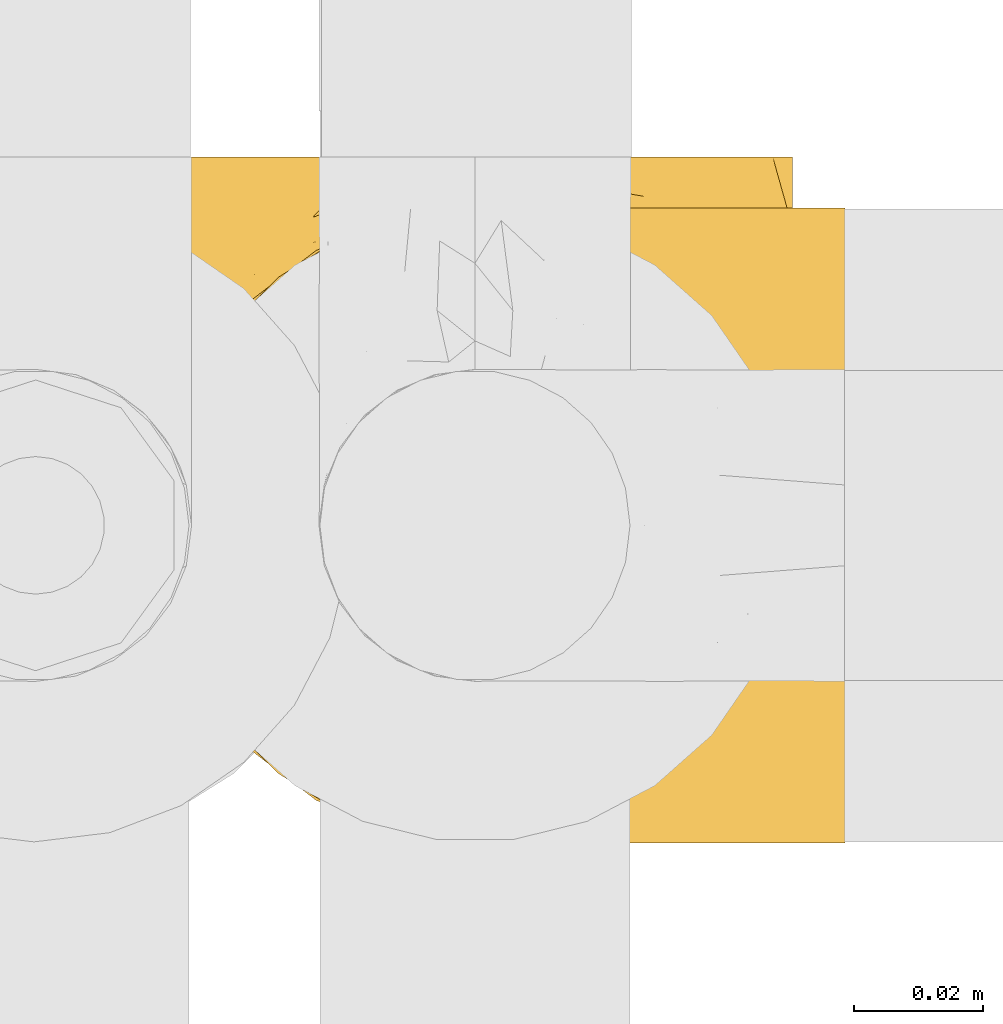
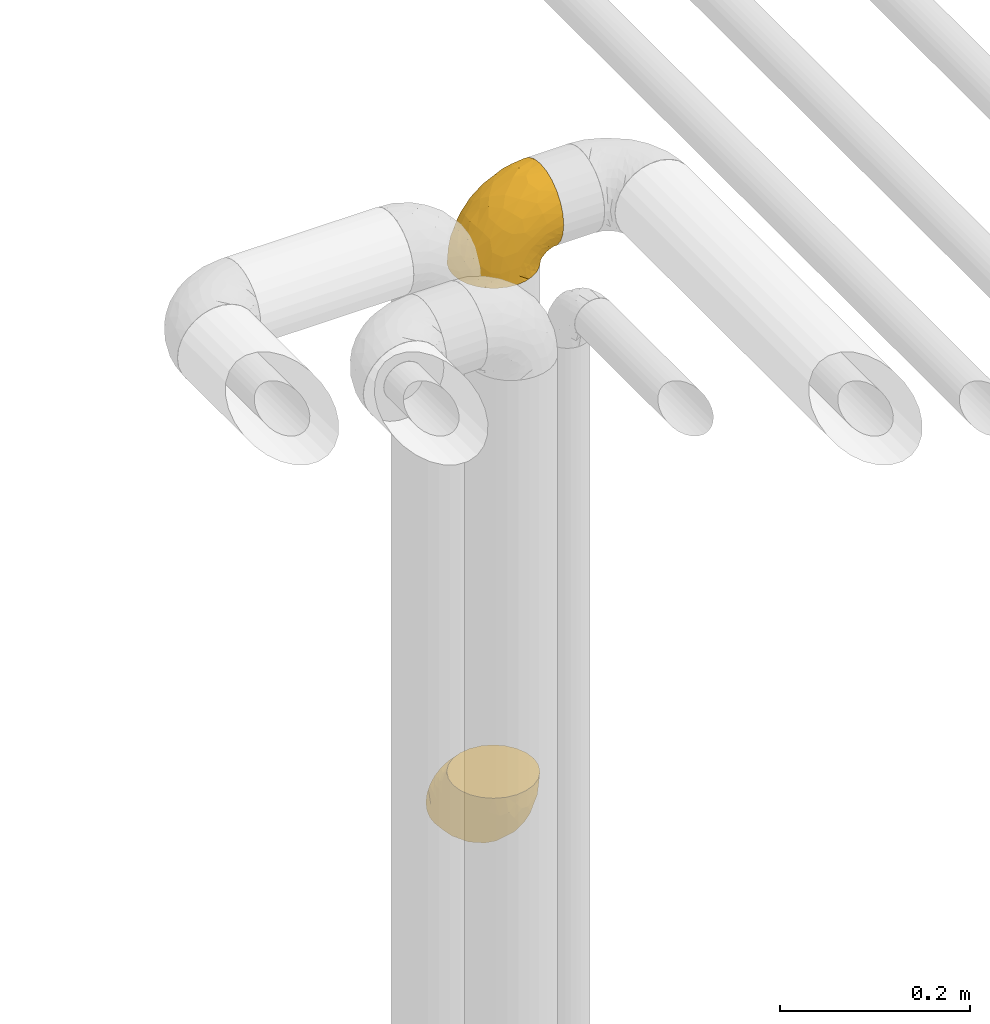
# One storey, part 402 of 827: 2 coverings.
"""IFC2X3 building model written with IfcOpenShell, lengths in millimetres."""

from ifc_helpers import new_model, entity, si_unit, converted_unit, derived_unit, direction, frame, origin, place, context, subcontext, project, spatial, faceted_brep, element, save


model = new_model("IFC2X3")

# Units and contexts
model_context = context("Model", 3, precision=0.01, world=origin(), true_north=direction((6.12303176911189e-17, 1.0)))
body_context = subcontext(model_context, "Body", "Model", "MODEL_VIEW")
ifc_project = project(units=[si_unit("LENGTHUNIT", "METRE", prefix="MILLI"), si_unit("AREAUNIT", "SQUARE_METRE"), si_unit("VOLUMEUNIT", "CUBIC_METRE"), converted_unit("PLANEANGLEUNIT", "DEGREE", entity("IfcRatioMeasure", 0.0174532925199433), si_unit("PLANEANGLEUNIT", "RADIAN"), dimensions=[0, 0, 0, 0, 0, 0, 0]), si_unit("MASSUNIT", "GRAM", prefix="KILO"), derived_unit("MASSDENSITYUNIT", [(si_unit("MASSUNIT", "GRAM", prefix="KILO"), 1), (si_unit("LENGTHUNIT", "METRE"), -3)]), derived_unit("MOMENTOFINERTIAUNIT", [(si_unit("LENGTHUNIT", "METRE"), 4)]), si_unit("TIMEUNIT", "SECOND"), si_unit("FREQUENCYUNIT", "HERTZ"), si_unit("THERMODYNAMICTEMPERATUREUNIT", "DEGREE_CELSIUS"), derived_unit("THERMALTRANSMITTANCEUNIT", [(si_unit("MASSUNIT", "GRAM", prefix="KILO"), 1), (si_unit("THERMODYNAMICTEMPERATUREUNIT", "KELVIN"), -1), (si_unit("TIMEUNIT", "SECOND"), -3)]), derived_unit("VOLUMETRICFLOWRATEUNIT", [(si_unit("LENGTHUNIT", "METRE"), 3), (si_unit("TIMEUNIT", "SECOND"), -1)]), derived_unit("MASSFLOWRATEUNIT", [(si_unit("MASSUNIT", "GRAM", prefix="KILO"), 1), (si_unit("TIMEUNIT", "SECOND"), -1)]), derived_unit("ROTATIONALFREQUENCYUNIT", [(si_unit("TIMEUNIT", "SECOND"), -1)]), si_unit("ELECTRICCURRENTUNIT", "AMPERE"), si_unit("ELECTRICVOLTAGEUNIT", "VOLT"), si_unit("POWERUNIT", "WATT"), si_unit("FORCEUNIT", "NEWTON", prefix="KILO"), si_unit("ILLUMINANCEUNIT", "LUX"), si_unit("LUMINOUSFLUXUNIT", "LUMEN"), si_unit("LUMINOUSINTENSITYUNIT", "CANDELA"), derived_unit("USERDEFINED", [(si_unit("MASSUNIT", "GRAM", prefix="KILO"), -1), (si_unit("LENGTHUNIT", "METRE"), -2), (si_unit("TIMEUNIT", "SECOND"), 3), (si_unit("LUMINOUSFLUXUNIT", "LUMEN"), 1)]), derived_unit("LINEARVELOCITYUNIT", [(si_unit("LENGTHUNIT", "METRE"), 1), (si_unit("TIMEUNIT", "SECOND"), -1)]), si_unit("PRESSUREUNIT", "PASCAL"), derived_unit("USERDEFINED", [(si_unit("LENGTHUNIT", "METRE"), -2), (si_unit("MASSUNIT", "GRAM", prefix="KILO"), 1), (si_unit("TIMEUNIT", "SECOND"), -2)]), derived_unit("LINEARFORCEUNIT", [(si_unit("MASSUNIT", "GRAM", prefix="KILO"), 1), (si_unit("LENGTHUNIT", "METRE"), 1), (si_unit("TIMEUNIT", "SECOND"), -2), (si_unit("LENGTHUNIT", "METRE"), -1)]), derived_unit("PLANARFORCEUNIT", [(si_unit("MASSUNIT", "GRAM", prefix="KILO"), 1), (si_unit("LENGTHUNIT", "METRE"), 1), (si_unit("TIMEUNIT", "SECOND"), -2), (si_unit("LENGTHUNIT", "METRE"), -2)])], contexts=[model_context])

# Site, building, storey
site_placement = place(None, origin())
site = spatial("IfcSite", under=ifc_project, at=site_placement, CompositionType="ELEMENT")
building_placement = place(site_placement, origin())
building = spatial("IfcBuilding", under=site, at=building_placement, CompositionType="ELEMENT")
storey_placement = place(building_placement, frame((0.0, 0.0, 28200.0)))
storey = spatial("IfcBuildingStorey", under=building, at=storey_placement, Name="08", CompositionType="ELEMENT", Elevation=28200.0)

# Coverings
covering_1_placement = place(storey_placement, frame((47669.52, 15256.28, 2941.4)))
element("IfcCovering", 1, at=covering_1_placement, inside=storey, Name=":ADSK_", ObjectType=":ADSK_", PredefinedType="INSULATION", context=body_context, shape_type="Brep", body=[
    faceted_brep([(50.75, 1.6, 1.6), (39.8, 2.83, 1.6), (29.41, 6.47, 1.6), (20.09, 12.32, 1.6), (12.31, 20.11, 1.6), (6.46, 29.43, 1.6), (2.83, 39.81, 1.6), (1.6, 50.75, 1.6), (2.83, 61.69, 1.6), (6.47, 72.08, 1.6), (12.32, 81.4, 1.6), (20.11, 89.18, 1.6), (29.43, 95.03, 1.6), (39.81, 98.66, 1.6), (50.75, 99.9, 1.6), (56.45, 99.25, 1.6), (61.69, 98.66, 1.6), (66.88, 96.84, 1.6), (72.08, 95.02, 1.6), (81.4, 89.17, 1.6), (89.18, 81.38, 1.6), (95.03, 72.06, 1.6), (98.66, 61.68, 1.6), (99.9, 50.75, 1.6), (98.66, 39.8, 1.6), (95.02, 29.41, 1.6), (89.17, 20.09, 1.6), (81.38, 12.31, 1.6), (72.06, 6.46, 1.6), (66.87, 4.64, 1.6), (61.68, 2.83, 1.6), (56.45, 2.24, 1.6), (53.6, 1.92, 1.6), (107.75, 63.47, 11.12), (107.75, 75.32, 16.03), (107.75, 80.41, 19.94), (107.75, 85.5, 23.84), (107.75, 89.4, 28.93), (107.75, 93.31, 34.02), (107.75, 95.77, 39.95), (107.75, 98.22, 45.87), (107.75, 99.14, 52.86), (107.75, 99.52, 55.73), (107.75, 99.9, 58.6), (107.75, 98.22, 71.32), (107.75, 93.31, 83.17), (107.75, 85.5, 93.35), (107.75, 75.32, 101.16), (107.75, 63.47, 106.07), (107.75, 50.75, 107.75), (107.75, 38.02, 106.07), (107.75, 26.17, 101.16), (107.75, 15.99, 93.35), (107.75, 8.18, 83.17), (107.75, 3.27, 71.32), (107.75, 1.6, 58.6), (107.75, 2.35, 52.86), (107.75, 3.27, 45.87), (107.75, 5.73, 39.95), (107.75, 8.18, 34.02), (107.75, 12.09, 28.93), (107.75, 15.99, 23.84), (107.75, 21.08, 19.94), (107.75, 26.17, 16.03), (107.75, 38.02, 11.12), (107.75, 50.75, 9.45), (39.38, 42.18, 81.82), (49.75, 28.42, 84.02), (57.38, 37.78, 93.05), (74.94, 50.75, 102.55), (85.97, 42.85, 104.83), (95.66, 50.75, 105.83), (67.82, 24.75, 91.87), (83.09, 33.81, 101.74), (89.16, 22.57, 97.07), (37.01, 7.18, 38.45), (43.46, 2.73, 22.17), (51.79, 3.09, 42.04), (85.58, 6.92, 77.69), (62.84, 11.58, 75.76), (62.77, 5.17, 62.11), (88.17, 2.71, 66.08), (85.93, 1.6, 54.26), (91.42, 1.6, 55.35), (96.91, 1.6, 56.44), (99.62, 1.6, 56.98), (102.33, 1.6, 57.52), (82.57, 14.18, 87.84), (32.75, 5.88, 19.41), (13.79, 41.06, 48.89), (6.77, 36.25, 26.34), (16.46, 28.62, 44.55), (55.08, 1.6, 23.41), (58.17, 1.6, 28.03), (61.26, 1.6, 32.65), (64.35, 1.6, 37.28), (67.44, 1.6, 41.9), (24.18, 10.85, 20.6), (23.37, 38.35, 63.36), (49.76, 9.6, 62.21), (9.84, 26.24, 19.94), (3.51, 50.75, 13.68), (55.75, 19.31, 80.85), (42.34, 16.41, 66.53), (37.78, 24.56, 71.06), (21.87, 50.75, 63.99), (33.61, 50.75, 75.73), (17.1, 18.47, 26.77), (51.28, 1.6, 4.31), (51.82, 1.6, 7.01), (52.9, 1.6, 12.43), (53.99, 1.6, 17.92), (28.01, 14.36, 43.43), (28.99, 20.64, 56.23), (69.9, 2.32, 54.97), (6.79, 50.75, 34.4), (72.06, 1.6, 44.99), (76.69, 1.6, 48.08), (81.31, 1.6, 51.17), (45.35, 50.75, 87.47), (34.79, 33.88, 74.55), (25.72, 29.24, 60.86), (14.33, 50.75, 49.19), (60.15, 50.75, 95.01), (62.38, 2.8, 10.27), (100.57, 2.48, 48.79), (91.06, 2.7, 45.16), (97.66, 3.2, 44.99), (97.55, 32.98, 6.17), (93.65, 24.67, 7.65), (66.85, 2.95, 21.59), (61.93, 2.19, 19.96), (101.4, 17.92, 21.0), (100.07, 12.02, 27.2), (101.36, 25.73, 14.83), (95.94, 16.63, 19.7), (96.3, 25.6, 10.93), (101.98, 36.72, 9.63), (85.88, 10.66, 19.97), (78.88, 6.87, 21.13), (82.8, 11.12, 14.14), (102.58, 10.31, 30.2), (82.88, 12.84, 8.12), (88.57, 17.38, 9.93), (88.67, 9.74, 24.62), (69.08, 4.63, 11.87), (102.19, 50.75, 7.15), (100.06, 42.52, 5.32), (70.56, 3.12, 26.68), (91.07, 17.58, 13.92), (77.56, 3.97, 30.67), (96.59, 5.94, 36.65), (86.38, 2.73, 42.89), (91.79, 6.23, 34.04), (81.71, 3.45, 36.6), (94.11, 10.84, 26.41), (76.09, 7.98, 10.07), (76.91, 7.33, 15.83), (81.44, 2.39, 41.99), (101.37, 75.76, 14.83), (94.12, 90.65, 26.4), (101.41, 83.57, 21.01), (95.96, 84.85, 19.71), (96.22, 71.05, 5.72), (66.85, 98.54, 21.6), (61.94, 99.3, 19.96), (58.17, 99.9, 28.03), (69.1, 96.86, 11.87), (88.58, 84.1, 9.93), (96.91, 99.9, 56.44), (102.33, 99.9, 57.52), (105.04, 99.9, 58.06), (82.9, 88.63, 8.13), (82.82, 90.36, 14.15), (97.66, 98.29, 44.99), (96.59, 95.55, 36.65), (100.07, 89.47, 27.21), (91.79, 95.26, 34.04), (102.58, 91.18, 30.2), (76.13, 93.49, 10.06), (76.93, 94.15, 15.83), (100.57, 99.01, 48.79), (86.38, 98.76, 42.89), (90.86, 98.85, 45.38), (52.9, 99.9, 12.43), (62.39, 98.69, 10.28), (101.98, 64.78, 9.64), (91.42, 99.9, 55.35), (85.93, 99.9, 54.26), (99.49, 62.91, 6.05), (51.82, 99.9, 7.01), (52.36, 99.9, 9.72), (61.26, 99.9, 32.65), (70.56, 98.37, 26.68), (91.09, 83.9, 13.92), (64.35, 99.9, 37.28), (77.6, 97.51, 30.66), (78.89, 94.62, 21.14), (81.71, 98.04, 36.59), (88.69, 91.73, 24.6), (53.99, 99.9, 17.92), (55.08, 99.9, 23.41), (96.31, 75.87, 10.93), (85.9, 90.83, 19.97), (81.45, 99.1, 41.99), (76.69, 99.9, 48.08), (81.31, 99.9, 51.17), (72.06, 99.9, 44.99), (67.44, 99.9, 41.9), (69.6, 99.09, 55.26), (85.97, 58.64, 104.83), (82.57, 87.31, 87.84), (63.16, 89.93, 75.91), (55.81, 82.22, 80.84), (67.81, 76.74, 91.87), (49.73, 73.12, 83.98), (32.55, 95.54, 19.16), (43.23, 98.7, 22.37), (88.17, 98.79, 66.08), (57.38, 63.71, 93.05), (83.08, 67.68, 101.74), (89.16, 78.92, 97.07), (85.58, 94.57, 77.69), (16.46, 72.88, 44.55), (6.77, 65.25, 26.34), (13.8, 60.44, 48.9), (37.71, 76.94, 70.99), (34.8, 67.61, 74.55), (36.83, 94.38, 37.8), (39.38, 59.31, 81.82), (17.12, 83.03, 26.77), (24.19, 90.66, 20.6), (28.89, 80.8, 56.15), (25.69, 72.22, 60.85), (51.77, 98.39, 42.06), (45.66, 92.31, 57.03), (23.39, 63.11, 63.4), (9.85, 75.27, 19.94), (28.11, 87.15, 43.59), (62.27, 96.03, 62.61), (42.35, 85.1, 66.52)], [[[0, 1, 2, 3, 4, 5, 6, 7, 8, 9, 10, 11, 12, 13, 14, 15, 16, 17, 18, 19, 20, 21, 22, 23, 24, 25, 26, 27, 28, 29, 30, 31, 32]], [[33, 34, 35, 36, 37, 38, 39, 40, 41, 42, 43, 44, 45, 46, 47, 48, 49, 50, 51, 52, 53, 54, 55, 56, 57, 58, 59, 60, 61, 62, 63, 64, 65]], [[66, 67, 68]], [[69, 70, 71]], [[68, 72, 73]], [[73, 72, 74]], [[75, 76, 77]], [[78, 79, 80]], [[51, 50, 73]], [[81, 82, 83, 84, 85, 86, 55]], [[52, 87, 53]], [[74, 52, 51]], [[2, 1, 88]], [[89, 90, 91]], [[77, 92, 93, 94, 95, 96]], [[55, 54, 81]], [[78, 53, 87]], [[5, 90, 6]], [[88, 76, 75]], [[97, 3, 2]], [[89, 91, 98]], [[99, 80, 79]], [[90, 5, 100]], [[74, 87, 52]], [[100, 5, 4]], [[90, 101, 6]], [[79, 102, 103]], [[102, 67, 104]], [[105, 98, 106]], [[107, 4, 3]], [[76, 0, 108, 109, 110, 111, 92]], [[107, 112, 113]], [[114, 77, 96]], [[89, 115, 90]], [[114, 96, 116, 117, 118, 82]], [[75, 97, 88]], [[119, 66, 68]], [[50, 71, 70]], [[100, 91, 90]], [[99, 77, 80]], [[102, 104, 103]], [[97, 107, 3]], [[80, 81, 78]], [[107, 97, 112]], [[68, 73, 70]], [[66, 98, 120]], [[78, 81, 54]], [[114, 81, 80]], [[53, 78, 54]], [[78, 87, 79]], [[102, 87, 72]], [[79, 103, 99]], [[4, 107, 100]], [[91, 100, 107]], [[88, 97, 2]], [[112, 97, 75]], [[99, 112, 75]], [[103, 104, 113]], [[91, 121, 98]], [[89, 105, 122, 115]], [[101, 90, 115]], [[101, 7, 6]], [[88, 1, 76]], [[0, 76, 1]], [[92, 77, 76]], [[73, 74, 51]], [[87, 74, 72]], [[81, 114, 82]], [[77, 114, 80]], [[87, 102, 79]], [[67, 102, 72]], [[68, 67, 72]], [[67, 120, 104]], [[120, 121, 104]], [[104, 121, 113]], [[121, 120, 98]], [[91, 107, 113]], [[91, 113, 121]], [[103, 113, 112]], [[106, 98, 66]], [[105, 89, 98]], [[106, 66, 119]], [[67, 66, 120]], [[68, 69, 123, 119]], [[50, 49, 71]], [[50, 70, 73]], [[112, 99, 103]], [[77, 99, 75]], [[69, 68, 70]], [[29, 124, 110]], [[84, 83, 125]], [[126, 82, 118]], [[59, 58, 127]], [[25, 128, 129]], [[130, 93, 131]], [[132, 62, 133]], [[134, 135, 136]], [[137, 65, 64]], [[64, 134, 137]], [[138, 139, 140]], [[111, 110, 124, 92]], [[134, 136, 137]], [[134, 64, 63]], [[141, 61, 60]], [[125, 58, 57]], [[142, 143, 140]], [[142, 26, 143]], [[127, 83, 82]], [[28, 124, 29]], [[108, 0, 32, 31, 30, 110, 109]], [[30, 29, 110]], [[135, 144, 138]], [[28, 145, 124]], [[57, 56, 55, 86, 85, 84]], [[146, 147, 23]], [[24, 23, 147]], [[25, 143, 26]], [[95, 94, 148]], [[24, 128, 25]], [[149, 138, 143]], [[124, 145, 131]], [[127, 58, 125]], [[150, 148, 139]], [[127, 126, 151]], [[151, 59, 127]], [[152, 151, 126]], [[153, 154, 155]], [[153, 133, 141]], [[145, 28, 27]], [[142, 156, 27]], [[157, 148, 130]], [[61, 133, 62]], [[134, 132, 135]], [[147, 128, 24]], [[65, 137, 146]], [[146, 137, 147]], [[128, 137, 136]], [[137, 128, 147]], [[128, 136, 129]], [[149, 129, 136]], [[25, 129, 143]], [[158, 152, 117]], [[152, 118, 117]], [[153, 151, 152]], [[158, 116, 154]], [[144, 150, 138]], [[153, 152, 158]], [[133, 153, 155]], [[133, 155, 132]], [[60, 151, 141]], [[135, 132, 155]], [[134, 63, 132]], [[144, 135, 155]], [[135, 138, 149]], [[155, 154, 144]], [[150, 154, 96]], [[154, 150, 144]], [[148, 94, 130]], [[82, 126, 127]], [[118, 152, 126]], [[150, 96, 95]], [[139, 148, 157]], [[150, 95, 148]], [[93, 92, 131]], [[130, 145, 156]], [[130, 94, 93]], [[84, 125, 57]], [[127, 125, 83]], [[140, 139, 157]], [[150, 139, 138]], [[140, 157, 142]], [[138, 140, 143]], [[156, 142, 157]], [[27, 26, 142]], [[130, 156, 157]], [[145, 27, 156]], [[132, 63, 62]], [[124, 131, 92]], [[130, 131, 145]], [[129, 149, 143]], [[135, 149, 136]], [[141, 133, 61]], [[60, 59, 151]], [[141, 151, 153]], [[116, 96, 154]], [[153, 158, 154]], [[158, 117, 116]], [[34, 33, 159]], [[160, 161, 162]], [[22, 21, 163]], [[164, 165, 166]], [[19, 18, 167]], [[168, 21, 20]], [[42, 41, 40, 169, 170, 171, 43]], [[172, 173, 168]], [[174, 38, 175]], [[176, 177, 178]], [[179, 164, 180]], [[40, 181, 169]], [[182, 183, 175]], [[17, 184, 185]], [[65, 146, 186]], [[187, 174, 188]], [[23, 22, 189]], [[174, 39, 38]], [[15, 14, 190, 191, 184, 16]], [[181, 40, 39]], [[192, 193, 164]], [[194, 163, 168]], [[33, 186, 159]], [[180, 173, 172]], [[195, 196, 193]], [[18, 185, 167]], [[173, 180, 197]], [[198, 199, 196]], [[200, 201, 185, 184]], [[184, 17, 16]], [[18, 17, 185]], [[202, 159, 186]], [[194, 168, 203]], [[189, 163, 202]], [[204, 205, 182]], [[187, 181, 174]], [[160, 177, 176]], [[206, 183, 182]], [[206, 182, 205]], [[201, 165, 185]], [[165, 164, 167]], [[172, 179, 180]], [[202, 194, 162]], [[176, 161, 160]], [[65, 186, 33]], [[163, 189, 22]], [[175, 177, 182]], [[174, 183, 188]], [[177, 198, 204]], [[199, 160, 162]], [[198, 207, 204]], [[175, 38, 37]], [[198, 177, 160]], [[178, 177, 175]], [[176, 35, 161]], [[34, 159, 161]], [[162, 161, 159]], [[202, 162, 159]], [[199, 162, 203]], [[196, 199, 203]], [[198, 160, 199]], [[193, 197, 180]], [[208, 198, 196]], [[188, 183, 206]], [[175, 183, 174]], [[193, 192, 195]], [[195, 208, 196]], [[197, 196, 203]], [[180, 164, 193]], [[168, 163, 21]], [[166, 165, 201]], [[166, 192, 164]], [[189, 202, 186]], [[186, 146, 189]], [[23, 189, 146]], [[174, 181, 39]], [[169, 181, 187]], [[196, 197, 193]], [[173, 203, 168]], [[203, 173, 197]], [[172, 168, 20]], [[20, 19, 172]], [[179, 172, 19]], [[19, 167, 179]], [[164, 179, 167]], [[35, 176, 36]], [[35, 34, 161]], [[185, 165, 167]], [[162, 194, 203]], [[163, 194, 202]], [[176, 178, 36]], [[37, 36, 178]], [[175, 37, 178]], [[177, 204, 182]], [[207, 198, 208]], [[207, 205, 204]], [[209, 188, 206, 205, 207, 208]], [[48, 210, 71]], [[211, 212, 213]], [[214, 213, 215]], [[216, 217, 13]], [[218, 43, 171, 170, 169, 187, 188]], [[219, 220, 214]], [[47, 46, 221]], [[210, 48, 220]], [[211, 222, 212]], [[222, 45, 44]], [[221, 220, 47]], [[47, 220, 48]], [[221, 211, 214]], [[223, 224, 225]], [[211, 46, 45]], [[226, 227, 215]], [[43, 218, 44]], [[217, 216, 228]], [[219, 215, 229]], [[14, 13, 217]], [[224, 9, 8]], [[10, 230, 11]], [[11, 231, 12]], [[232, 223, 233]], [[234, 208, 195, 192, 166, 201]], [[235, 234, 228]], [[222, 44, 218]], [[106, 229, 236]], [[224, 237, 9]], [[231, 238, 228]], [[9, 237, 10]], [[115, 224, 101]], [[239, 234, 235]], [[231, 11, 230]], [[223, 230, 237]], [[224, 8, 101]], [[223, 236, 233]], [[225, 115, 122, 105]], [[216, 12, 231]], [[209, 234, 239]], [[210, 219, 69]], [[219, 214, 215]], [[229, 119, 219]], [[209, 218, 188]], [[239, 212, 222]], [[239, 222, 218]], [[45, 222, 211]], [[235, 212, 239]], [[213, 212, 240]], [[223, 237, 224]], [[230, 10, 237]], [[238, 231, 230]], [[216, 231, 228]], [[232, 230, 223]], [[235, 238, 240]], [[115, 225, 224]], [[233, 236, 227]], [[8, 7, 101]], [[234, 209, 208]], [[218, 209, 239]], [[217, 228, 234]], [[13, 12, 216]], [[234, 201, 217]], [[217, 201, 200, 184, 191, 190, 14]], [[211, 221, 46]], [[220, 221, 214]], [[71, 210, 69]], [[71, 49, 48]], [[219, 210, 220]], [[226, 215, 213]], [[211, 213, 214]], [[226, 213, 240]], [[215, 227, 229]], [[232, 240, 238]], [[233, 227, 226]], [[232, 233, 226]], [[236, 223, 225]], [[240, 232, 226]], [[232, 238, 230]], [[225, 105, 236]], [[236, 105, 106]], [[236, 229, 227]], [[123, 69, 219, 119]], [[106, 119, 229]], [[238, 235, 228]], [[212, 235, 240]]]),
])
covering_2_placement = place(storey_placement, frame((47669.27, 15256.28, 2179.88)))
element("IfcCovering", 2, at=covering_2_placement, inside=storey, Name=":ADSK_", ObjectType=":ADSK_", PredefinedType="INSULATION", context=body_context, shape_type="Brep", body=[
    faceted_brep([(99.9, 107.75, 50.75), (98.66, 107.75, 39.8), (95.02, 107.75, 29.41), (89.17, 107.75, 20.09), (81.38, 107.75, 12.31), (72.06, 107.75, 6.46), (61.68, 107.75, 2.83), (50.75, 107.75, 1.6), (39.8, 107.75, 2.83), (29.41, 107.75, 6.47), (20.09, 107.75, 12.32), (12.31, 107.75, 20.11), (6.46, 107.75, 29.43), (2.83, 107.75, 39.81), (1.6, 107.75, 50.75), (2.24, 107.75, 56.45), (2.83, 107.75, 61.69), (4.65, 107.75, 66.88), (6.47, 107.75, 72.08), (12.32, 107.75, 81.4), (20.11, 107.75, 89.18), (29.43, 107.75, 95.03), (39.81, 107.75, 98.66), (50.75, 107.75, 99.9), (61.69, 107.75, 98.66), (72.08, 107.75, 95.02), (81.4, 107.75, 89.17), (89.18, 107.75, 81.38), (95.03, 107.75, 72.06), (96.85, 107.75, 66.87), (98.66, 107.75, 61.68), (99.25, 107.75, 56.45), (99.57, 107.75, 53.6), (38.02, 98.22, 107.75), (26.17, 93.31, 107.75), (21.08, 89.4, 107.75), (15.99, 85.5, 107.75), (12.09, 80.41, 107.75), (8.18, 75.32, 107.75), (5.73, 69.39, 107.75), (3.27, 63.47, 107.75), (2.35, 56.48, 107.75), (1.97, 53.61, 107.75), (1.6, 50.75, 107.75), (3.27, 38.02, 107.75), (8.18, 26.17, 107.75), (15.99, 15.99, 107.75), (26.17, 8.18, 107.75), (38.02, 3.27, 107.75), (50.75, 1.6, 107.75), (63.47, 3.27, 107.75), (75.32, 8.18, 107.75), (85.5, 15.99, 107.75), (93.31, 26.17, 107.75), (98.22, 38.02, 107.75), (99.9, 50.75, 107.75), (99.14, 56.48, 107.75), (98.22, 63.47, 107.75), (95.77, 69.39, 107.75), (93.31, 75.32, 107.75), (89.4, 80.41, 107.75), (85.5, 85.5, 107.75), (80.41, 89.4, 107.75), (75.32, 93.31, 107.75), (63.47, 98.22, 107.75), (50.75, 99.9, 107.75), (59.31, 27.53, 39.38), (73.08, 25.32, 49.75), (63.72, 16.29, 57.38), (50.75, 6.79, 74.94), (58.64, 4.51, 85.97), (50.75, 3.51, 95.66), (76.74, 17.47, 67.82), (67.68, 7.6, 83.09), (78.92, 12.27, 89.16), (94.31, 70.89, 37.01), (98.76, 87.17, 43.46), (98.4, 67.3, 51.79), (94.57, 31.65, 85.58), (89.91, 33.58, 62.84), (96.32, 47.23, 62.77), (98.79, 43.26, 88.17), (99.9, 55.08, 85.93), (99.9, 53.99, 91.42), (99.9, 52.9, 96.91), (99.9, 52.36, 99.62), (99.9, 51.82, 102.33), (87.31, 21.5, 82.57), (95.61, 89.94, 32.75), (60.43, 60.45, 13.79), (65.24, 83.0, 6.77), (72.87, 64.79, 16.46), (99.9, 85.93, 55.08), (99.9, 81.31, 58.17), (99.9, 76.69, 61.26), (99.9, 72.06, 64.35), (99.9, 67.44, 67.44), (90.65, 88.74, 24.18), (63.14, 45.98, 23.37), (91.89, 47.13, 49.76), (75.25, 89.4, 9.84), (50.75, 95.66, 3.51), (82.18, 28.5, 55.75), (85.08, 42.81, 42.34), (76.93, 38.28, 37.78), (50.75, 45.35, 21.87), (50.75, 33.61, 33.61), (83.02, 82.57, 17.1), (99.9, 105.04, 51.28), (99.9, 102.33, 51.82), (99.9, 96.91, 52.9), (99.9, 91.42, 53.99), (87.13, 65.92, 28.01), (80.85, 53.11, 28.99), (99.17, 54.37, 69.9), (50.75, 74.94, 6.79), (99.9, 64.35, 72.06), (99.9, 61.26, 76.69), (99.9, 58.17, 81.31), (50.75, 21.87, 45.35), (67.61, 34.79, 34.79), (72.25, 48.48, 25.72), (50.75, 60.15, 14.33), (50.75, 14.33, 60.15), (98.69, 99.07, 62.38), (99.01, 60.55, 100.57), (98.79, 64.18, 91.06), (98.29, 64.36, 97.66), (68.51, 103.17, 97.55), (76.82, 101.69, 93.65), (98.54, 87.75, 66.85), (99.3, 89.38, 61.93), (83.57, 88.34, 101.4), (89.47, 82.14, 100.07), (75.76, 94.51, 101.36), (84.86, 89.64, 95.94), (75.89, 98.41, 96.3), (64.77, 99.71, 101.98), (90.83, 89.37, 85.88), (94.62, 88.21, 78.88), (90.37, 95.2, 82.8), (91.18, 79.14, 102.58), (88.65, 101.22, 82.88), (84.11, 99.41, 88.57), (91.75, 84.72, 88.67), (96.86, 97.47, 69.08), (50.75, 102.19, 102.19), (58.97, 104.02, 100.06), (98.37, 82.66, 70.56), (83.91, 95.42, 91.07), (97.52, 78.67, 77.56), (95.55, 72.69, 96.59), (98.76, 66.46, 86.38), (95.26, 75.3, 91.79), (98.04, 72.74, 81.71), (90.65, 82.93, 94.11), (93.51, 99.27, 76.09), (94.16, 93.51, 76.91), (99.1, 67.35, 81.44), (25.73, 94.51, 101.37), (10.84, 82.94, 94.12), (17.92, 88.33, 101.41), (16.64, 89.64, 95.96), (30.44, 103.62, 96.22), (2.95, 87.74, 66.85), (2.19, 89.38, 61.94), (1.6, 81.31, 58.17), (4.63, 97.47, 69.1), (17.39, 99.41, 88.58), (1.6, 51.28, 105.04), (1.6, 52.9, 96.91), (1.6, 51.82, 102.33), (12.86, 101.21, 82.9), (11.13, 95.19, 82.82), (3.2, 64.36, 97.66), (5.94, 72.69, 96.59), (10.31, 79.14, 102.58), (8.0, 99.28, 76.13), (7.34, 93.51, 76.93), (2.48, 60.55, 100.57), (2.73, 66.46, 86.38), (2.64, 63.96, 90.86), (1.6, 96.91, 52.9), (2.8, 99.06, 62.39), (36.71, 99.7, 101.98), (1.6, 53.99, 91.42), (1.6, 55.08, 85.93), (38.59, 103.3, 99.49), (1.6, 102.33, 51.82), (1.6, 99.62, 52.36), (1.6, 76.69, 61.26), (3.12, 82.66, 70.56), (17.59, 95.42, 91.09), (1.6, 72.06, 64.35), (3.98, 78.68, 77.6), (6.87, 88.2, 78.89), (3.45, 72.75, 81.71), (9.76, 84.74, 88.69), (1.6, 91.42, 53.99), (1.6, 85.93, 55.08), (25.62, 98.41, 96.31), (10.67, 89.37, 85.9), (2.39, 67.35, 81.45), (1.6, 61.26, 76.69), (6.23, 75.3, 91.79), (12.02, 82.13, 100.07), (1.6, 58.17, 81.31), (1.6, 64.35, 72.06), (1.6, 67.44, 67.44), (2.4, 54.08, 69.6), (42.85, 4.51, 85.97), (14.18, 21.5, 82.57), (11.56, 33.43, 63.16), (19.27, 28.5, 55.81), (24.75, 17.47, 67.81), (28.37, 25.36, 49.73), (5.95, 90.18, 32.55), (2.79, 86.97, 43.23), (2.71, 43.26, 88.17), (37.78, 16.29, 57.38), (33.81, 7.6, 83.08), (22.57, 12.27, 89.16), (6.92, 31.65, 85.58), (28.61, 64.79, 16.46), (36.24, 83.0, 6.77), (41.05, 60.44, 13.8), (24.55, 38.35, 37.71), (33.88, 34.8, 34.8), (7.11, 71.54, 36.83), (38.38, 45.94, 23.39), (42.18, 27.53, 39.38), (18.46, 82.57, 17.12), (10.84, 88.74, 24.19), (20.69, 53.19, 28.89), (29.27, 48.49, 25.69), (3.1, 67.28, 51.77), (9.18, 52.32, 45.66), (26.23, 89.4, 9.85), (14.34, 65.75, 28.11), (5.46, 46.73, 62.27), (16.39, 42.82, 42.35)], [[[0, 1, 2, 3, 4, 5, 6, 7, 8, 9, 10, 11, 12, 13, 14, 15, 16, 17, 18, 19, 20, 21, 22, 23, 24, 25, 26, 27, 28, 29, 30, 31, 32]], [[33, 34, 35, 36, 37, 38, 39, 40, 41, 42, 43, 44, 45, 46, 47, 48, 49, 50, 51, 52, 53, 54, 55, 56, 57, 58, 59, 60, 61, 62, 63, 64, 65]], [[66, 67, 68]], [[69, 70, 71]], [[68, 72, 73]], [[73, 72, 74]], [[75, 76, 77]], [[78, 79, 80]], [[51, 50, 73]], [[81, 82, 83, 84, 85, 86, 55]], [[52, 87, 53]], [[74, 52, 51]], [[2, 1, 88]], [[89, 90, 91]], [[77, 92, 93, 94, 95, 96]], [[55, 54, 81]], [[78, 53, 87]], [[5, 90, 6]], [[88, 76, 75]], [[97, 3, 2]], [[89, 91, 98]], [[99, 80, 79]], [[90, 5, 100]], [[74, 87, 52]], [[100, 5, 4]], [[90, 101, 6]], [[79, 102, 103]], [[102, 67, 104]], [[105, 98, 106]], [[107, 4, 3]], [[76, 0, 108, 109, 110, 111, 92]], [[107, 112, 113]], [[114, 77, 96]], [[89, 115, 90]], [[114, 96, 116, 117, 118, 82]], [[75, 97, 88]], [[119, 66, 68]], [[50, 71, 70]], [[100, 91, 90]], [[99, 77, 80]], [[102, 104, 103]], [[97, 107, 3]], [[80, 81, 78]], [[107, 97, 112]], [[68, 73, 70]], [[66, 98, 120]], [[78, 81, 54]], [[114, 81, 80]], [[53, 78, 54]], [[78, 87, 79]], [[102, 87, 72]], [[79, 103, 99]], [[4, 107, 100]], [[91, 100, 107]], [[88, 97, 2]], [[112, 97, 75]], [[99, 112, 75]], [[103, 104, 113]], [[91, 121, 98]], [[89, 105, 122, 115]], [[101, 90, 115]], [[101, 7, 6]], [[88, 1, 76]], [[0, 76, 1]], [[92, 77, 76]], [[73, 74, 51]], [[87, 74, 72]], [[81, 114, 82]], [[77, 114, 80]], [[87, 102, 79]], [[67, 102, 72]], [[68, 67, 72]], [[67, 120, 104]], [[120, 121, 104]], [[104, 121, 113]], [[121, 120, 98]], [[91, 107, 113]], [[91, 113, 121]], [[103, 113, 112]], [[106, 98, 66]], [[105, 89, 98]], [[106, 66, 119]], [[67, 66, 120]], [[68, 69, 123, 119]], [[50, 49, 71]], [[50, 70, 73]], [[112, 99, 103]], [[77, 99, 75]], [[69, 68, 70]], [[29, 124, 110]], [[84, 83, 125]], [[126, 82, 118]], [[59, 58, 127]], [[25, 128, 129]], [[130, 93, 131]], [[132, 62, 133]], [[134, 135, 136]], [[137, 65, 64]], [[64, 134, 137]], [[138, 139, 140]], [[111, 110, 124, 92]], [[134, 136, 137]], [[134, 64, 63]], [[133, 61, 141]], [[125, 58, 57]], [[142, 143, 140]], [[142, 26, 143]], [[127, 83, 82]], [[28, 124, 29]], [[108, 0, 32, 31, 30, 110, 109]], [[30, 29, 110]], [[135, 144, 138]], [[28, 145, 124]], [[57, 56, 55, 86, 85, 84]], [[146, 147, 23]], [[24, 23, 147]], [[25, 143, 26]], [[95, 94, 148]], [[24, 128, 25]], [[149, 138, 143]], [[124, 145, 131]], [[127, 58, 125]], [[150, 148, 139]], [[127, 126, 151]], [[151, 59, 127]], [[152, 151, 126]], [[153, 154, 155]], [[153, 133, 141]], [[145, 28, 27]], [[142, 156, 27]], [[157, 148, 130]], [[61, 133, 62]], [[134, 132, 135]], [[147, 128, 24]], [[65, 137, 146]], [[146, 137, 147]], [[128, 137, 136]], [[137, 128, 147]], [[128, 136, 129]], [[149, 129, 136]], [[25, 129, 143]], [[158, 152, 117]], [[152, 118, 117]], [[153, 151, 152]], [[158, 116, 154]], [[144, 150, 138]], [[153, 152, 158]], [[133, 153, 155]], [[133, 155, 132]], [[141, 61, 60]], [[135, 132, 155]], [[134, 63, 132]], [[144, 135, 155]], [[135, 138, 149]], [[155, 154, 144]], [[150, 154, 96]], [[154, 150, 144]], [[148, 94, 130]], [[82, 126, 127]], [[118, 152, 126]], [[150, 96, 95]], [[139, 148, 157]], [[150, 95, 148]], [[93, 92, 131]], [[130, 145, 156]], [[130, 94, 93]], [[84, 125, 57]], [[127, 125, 83]], [[140, 139, 157]], [[150, 139, 138]], [[140, 157, 142]], [[138, 140, 143]], [[156, 142, 157]], [[27, 26, 142]], [[130, 156, 157]], [[145, 27, 156]], [[132, 63, 62]], [[124, 131, 92]], [[130, 131, 145]], [[129, 149, 143]], [[135, 149, 136]], [[60, 151, 141]], [[59, 151, 60]], [[141, 151, 153]], [[116, 96, 154]], [[153, 158, 154]], [[158, 117, 116]], [[34, 33, 159]], [[160, 161, 162]], [[22, 21, 163]], [[164, 165, 166]], [[19, 18, 167]], [[168, 21, 20]], [[169, 43, 42, 41, 40, 170, 171]], [[172, 173, 168]], [[174, 38, 175]], [[37, 36, 176]], [[177, 164, 178]], [[40, 179, 170]], [[180, 181, 175]], [[17, 182, 183]], [[65, 146, 184]], [[185, 174, 186]], [[23, 22, 187]], [[174, 39, 38]], [[15, 14, 188, 189, 182, 16]], [[179, 40, 39]], [[190, 191, 164]], [[192, 163, 168]], [[33, 184, 159]], [[178, 173, 172]], [[193, 194, 191]], [[18, 183, 167]], [[173, 178, 195]], [[196, 197, 194]], [[198, 199, 183, 182]], [[182, 17, 16]], [[18, 17, 183]], [[200, 159, 184]], [[192, 168, 201]], [[187, 163, 200]], [[202, 203, 180]], [[185, 179, 174]], [[160, 204, 205]], [[206, 181, 180]], [[206, 180, 203]], [[199, 165, 183]], [[165, 164, 167]], [[172, 177, 178]], [[200, 192, 162]], [[205, 161, 160]], [[65, 184, 33]], [[163, 187, 22]], [[175, 204, 180]], [[174, 181, 186]], [[204, 196, 202]], [[197, 160, 162]], [[196, 207, 202]], [[37, 176, 175]], [[196, 204, 160]], [[176, 204, 175]], [[205, 35, 161]], [[34, 159, 161]], [[162, 161, 159]], [[200, 162, 159]], [[197, 162, 201]], [[194, 197, 201]], [[196, 160, 197]], [[191, 195, 178]], [[208, 196, 194]], [[186, 181, 206]], [[175, 181, 174]], [[191, 190, 193]], [[193, 208, 194]], [[195, 194, 201]], [[178, 164, 191]], [[168, 163, 21]], [[166, 165, 199]], [[166, 190, 164]], [[187, 200, 184]], [[184, 146, 187]], [[23, 187, 146]], [[174, 179, 39]], [[170, 179, 185]], [[194, 195, 191]], [[173, 201, 168]], [[201, 173, 195]], [[172, 168, 20]], [[20, 19, 172]], [[177, 172, 19]], [[19, 167, 177]], [[164, 177, 167]], [[35, 205, 36]], [[35, 34, 161]], [[183, 165, 167]], [[162, 192, 201]], [[163, 192, 200]], [[175, 38, 37]], [[36, 205, 176]], [[204, 176, 205]], [[204, 202, 180]], [[207, 196, 208]], [[207, 203, 202]], [[209, 186, 206, 203, 207, 208]], [[48, 210, 71]], [[211, 212, 213]], [[214, 213, 215]], [[216, 217, 13]], [[218, 43, 169, 171, 170, 185, 186]], [[219, 220, 214]], [[47, 46, 221]], [[210, 48, 220]], [[211, 222, 212]], [[222, 45, 44]], [[221, 220, 47]], [[47, 220, 48]], [[221, 211, 214]], [[223, 224, 225]], [[211, 46, 45]], [[226, 227, 215]], [[43, 218, 44]], [[217, 216, 228]], [[227, 229, 230]], [[14, 13, 217]], [[224, 9, 8]], [[10, 231, 11]], [[11, 232, 12]], [[233, 223, 234]], [[235, 208, 193, 190, 166, 199]], [[236, 235, 228]], [[222, 44, 218]], [[106, 230, 229]], [[224, 237, 9]], [[232, 238, 228]], [[9, 237, 10]], [[115, 224, 101]], [[239, 235, 236]], [[232, 11, 231]], [[223, 231, 237]], [[224, 8, 101]], [[223, 229, 234]], [[225, 115, 122, 105]], [[216, 12, 232]], [[209, 235, 239]], [[210, 219, 69]], [[219, 214, 215]], [[230, 119, 219]], [[209, 218, 186]], [[239, 212, 222]], [[239, 222, 218]], [[45, 222, 211]], [[236, 212, 239]], [[213, 212, 240]], [[223, 237, 224]], [[231, 10, 237]], [[238, 232, 231]], [[216, 232, 228]], [[233, 231, 223]], [[236, 238, 240]], [[115, 225, 224]], [[234, 229, 227]], [[8, 7, 101]], [[235, 209, 208]], [[218, 209, 239]], [[217, 228, 235]], [[13, 12, 216]], [[235, 199, 217]], [[217, 199, 198, 182, 189, 188, 14]], [[211, 221, 46]], [[220, 221, 214]], [[71, 210, 69]], [[71, 49, 48]], [[219, 210, 220]], [[226, 215, 213]], [[211, 213, 214]], [[226, 213, 240]], [[215, 227, 230]], [[233, 240, 238]], [[234, 227, 226]], [[233, 234, 226]], [[229, 223, 225]], [[240, 233, 226]], [[233, 238, 231]], [[225, 105, 229]], [[229, 105, 106]], [[106, 119, 230]], [[123, 69, 219, 119]], [[215, 230, 219]], [[238, 236, 228]], [[212, 236, 240]]]),
])

save(model, "model.ifc")
